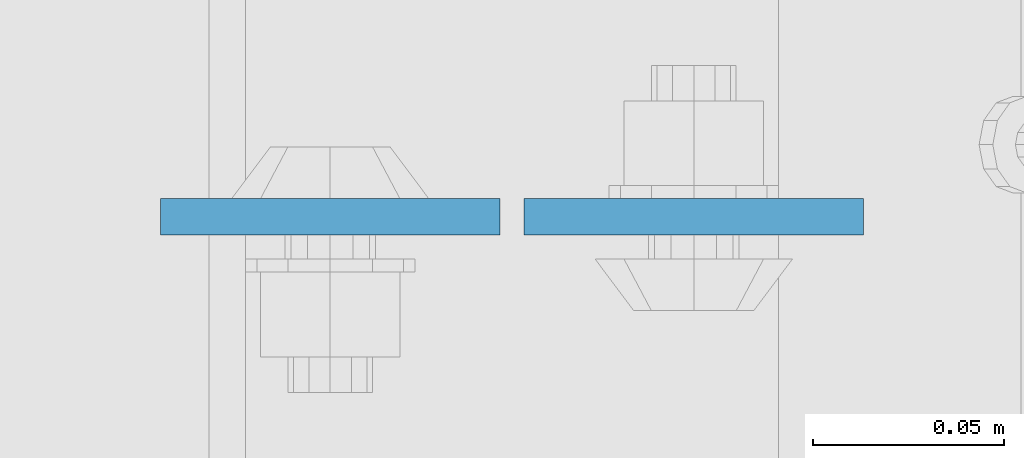
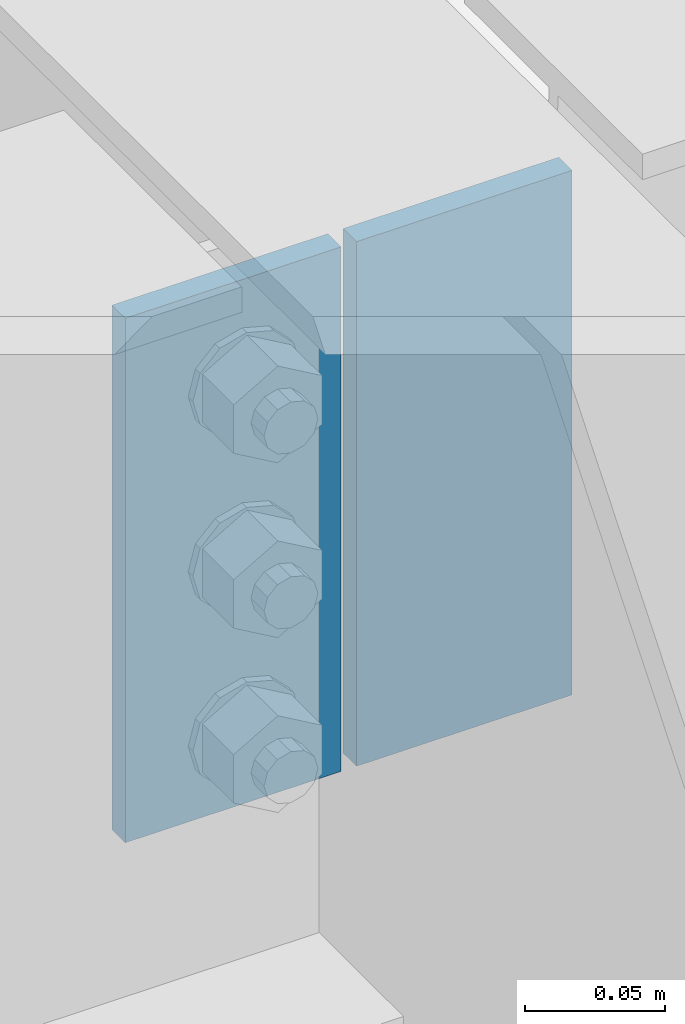
# One storey, part 3112 of 3843: 2 plates, 1 element without a shape of its own.
"""IFC2X3 building model written with IfcOpenShell, lengths in millimetres."""

from ifc_helpers import new_model, si_unit, frame, origin_with_axes, place, context, subcontext, project, spatial, faceted_brep, material, type_object, element, aggregate, save


model = new_model("IFC2X3")

# Units and contexts
model_context = context("Model", 3, precision=1e-05, world=origin_with_axes())
body_context = subcontext(model_context, "Body", "Model", "MODEL_VIEW")
ifc_project = project(units=[si_unit("LENGTHUNIT", "METRE", prefix="MILLI"), si_unit("AREAUNIT", "SQUARE_METRE"), si_unit("VOLUMEUNIT", "CUBIC_METRE"), si_unit("MASSUNIT", "GRAM", prefix="KILO"), si_unit("TIMEUNIT", "SECOND"), si_unit("PLANEANGLEUNIT", "RADIAN"), si_unit("SOLIDANGLEUNIT", "STERADIAN"), si_unit("THERMODYNAMICTEMPERATUREUNIT", "DEGREE_CELSIUS"), si_unit("LUMINOUSINTENSITYUNIT", "LUMEN")], contexts=[model_context])

# Site, building, storey
site_placement = place(None, origin_with_axes())
site = spatial("IfcSite", under=ifc_project, at=site_placement, CompositionType="ELEMENT")
building_placement = place(site_placement, origin_with_axes())
building = spatial("IfcBuilding", under=site, at=building_placement, Name="Undefined", CompositionType="ELEMENT")
storey_placement = place(building_placement, origin_with_axes())
storey = spatial("IfcBuildingStorey", under=building, at=storey_placement, Name="Undefined", CompositionType="ELEMENT", Elevation=0.0)

# Assembly, plates
assembly_placement = place(storey_placement, origin_with_axes())
assembly = element("IfcElementAssembly", 1, at=assembly_placement, inside=storey, Name="BEAM", AssemblyPlace="NOTDEFINED", PredefinedType="RIGID_FRAME")
ifc_material = material(Name="STEEL/A572-50")
plate_type = type_object("IfcPlateType", PredefinedType="NOTDEFINED")
plate_1_placement = place(assembly_placement, frame((55933.975, 17130.0775, 42418.0), z_axis=(1.0, 0.0, 0.0), x_axis=(0.0, 0.0, -1.0)))
plate_1 = element("IfcPlate", 2, at=plate_1_placement, type_object=plate_type, material=ifc_material, Name="PLATE", context=body_context, shape_type="Brep", body=[
    faceted_brep([(0.0, -4.76249999999709, 0.0), (0.0, -4.76249999999709, 88.9000015258789), (0.0, 4.76249999999709, 88.9000015258789), (0.0, 4.76249999999709, 0.0), (228.600006102781, -4.7625000004191, 88.9000015257589), (228.600006102781, 4.76249999954598, 88.9000015257443), (228.600006103079, -4.7625000004482, 7.27595761418343e-12), (228.600006103079, 4.76249999954598, -7.27595761418343e-12)], [[[0, 1, 2, 3]], [[1, 4, 5, 2]], [[4, 6, 7, 5]], [[6, 0, 3, 7]], [[5, 7, 3, 2]], [[6, 4, 1, 0]]]),
])
plate_2_placement = place(assembly_placement, frame((55927.625, 17130.0775, 42418.0), z_axis=(-1.0, 0.0, 0.0), x_axis=(0.0, 0.0, -1.0)))
plate_2 = element("IfcPlate", 3, at=plate_2_placement, type_object=plate_type, material=ifc_material, Name="PLATE", context=body_context, shape_type="Brep", body=[
    faceted_brep([(0.0, -4.76249999999709, 0.0), (0.0, -4.76249999999709, 88.9000015258789), (0.0, 4.76249999999709, 88.9000015258789), (0.0, 4.76249999999709, 0.0), (228.600006102781, -4.7625000004191, 88.9000015257589), (228.600006102781, 4.76249999954598, 88.9000015257443), (228.600006103079, -4.7625000004482, 7.27595761418343e-12), (228.600006103079, 4.76249999954598, -7.27595761418343e-12)], [[[0, 1, 2, 3]], [[1, 4, 5, 2]], [[4, 6, 7, 5]], [[6, 0, 3, 7]], [[5, 7, 3, 2]], [[6, 4, 1, 0]]]),
])
aggregate(assembly, [plate_1, plate_2])

save(model, "model.ifc")
